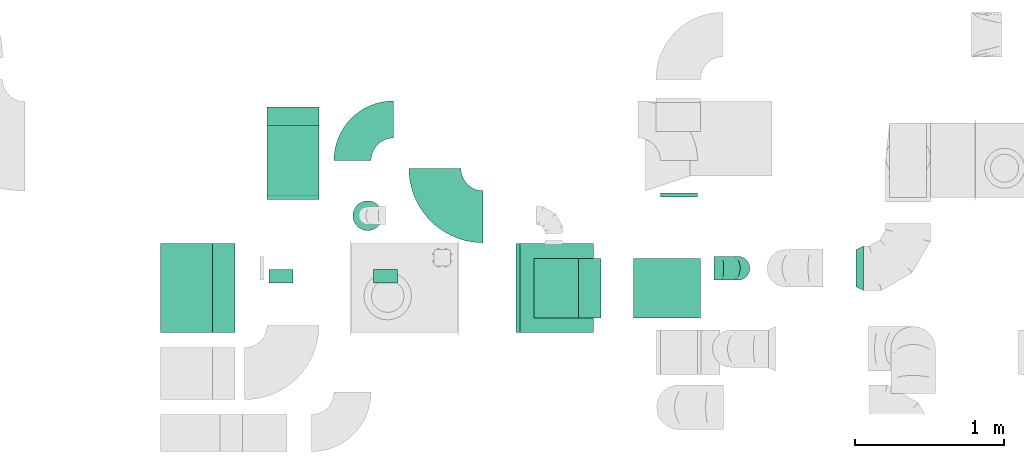
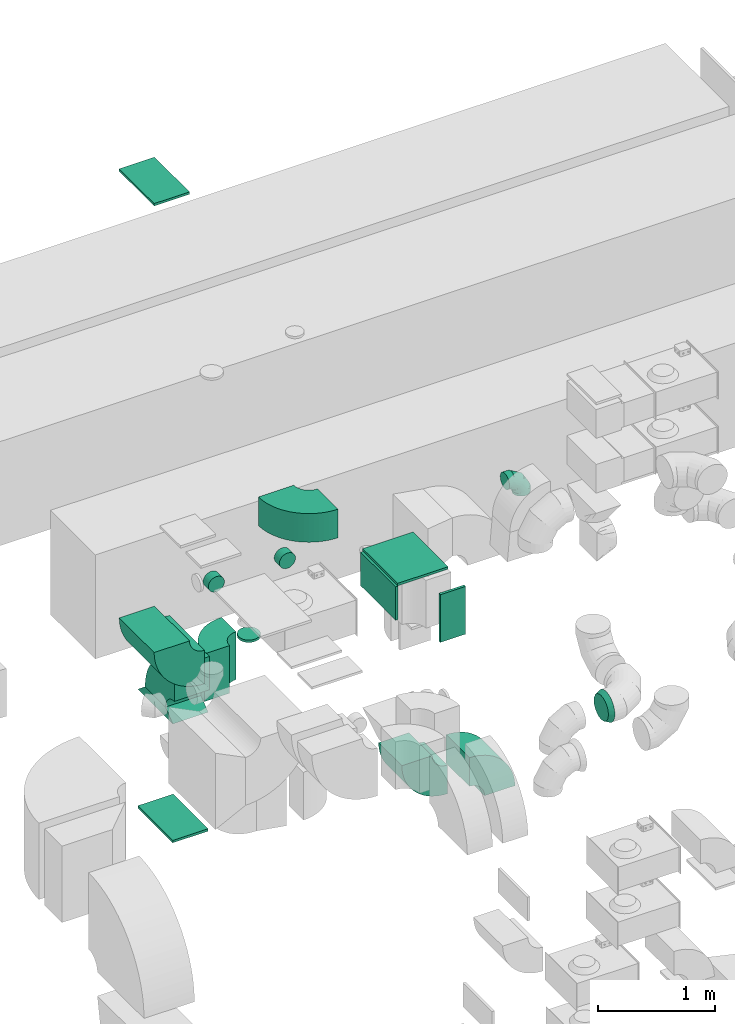
# One storey, part 10 of 59: 17 flow fittings.
"""IFC2X3 building model written with IfcOpenShell, lengths in millimetres."""

import ifcopenshell
import ifcopenshell.guid

model = None  # the IFC model being written
_history = None  # IfcOwnerHistory: only IFC2X3 demands one
_inside = {}  # id of a spatial element -> (the spatial element, [elements in it])
_under = {}  # id of a project, library or spatial element -> (it, [spatial elements below it])
_declared = {}  # id of a project -> (the project, [libraries it declares])
_typed = {}  # id of a type object -> (the type object, [elements of that type])
_made_of = {}  # id of a material, layer set ... -> (it, [elements and type objects made of it])


def new_model(schema):
    """Start an empty IFC model of exactly this schema.

    Asked for "IFC4X3", IfcOpenShell would pick the latest addendum, in which some entities
    have other attributes; the version numbers below select the first issue.
    IFC2X3 requires an IfcOwnerHistory on every rooted entity: one is made here for all.
    """
    global model, _history
    if schema == "IFC4X3":
        model = ifcopenshell.file(schema_version=(4, 3, 0, 0))
    else:
        model = ifcopenshell.file(schema=schema)
    _inside.clear()
    _under.clear()
    _declared.clear()
    _typed.clear()
    _made_of.clear()
    _history = None
    if model.schema == "IFC2X3":
        org = make("IfcOrganization", Name="unknown")
        user = make(
            "IfcPersonAndOrganization",
            ThePerson=make("IfcPerson", FamilyName="unknown"),
            TheOrganization=org,
        )
        app = make(
            "IfcApplication",
            ApplicationDeveloper=org,
            Version="unknown",
            ApplicationFullName="unknown",
            ApplicationIdentifier="unknown",
        )
        _history = make(
            "IfcOwnerHistory",
            OwningUser=user,
            OwningApplication=app,
            ChangeAction="ADDED",
            CreationDate=0,
        )
    return model


def make(cls, **values):
    """One entity of the class cls with the attributes given. An attribute that is None is left unset."""
    return model.create_entity(
        cls, **{name: value for name, value in values.items() if value is not None}
    )


def entity(cls, *values):
    """Any entity or typed value of the class cls, its attributes in the order of the schema. None: left unset."""
    e = model.create_entity(cls)
    for i, value in enumerate(values):
        if value is not None:
            e[i] = value
    return e


def rooted(cls, **values):
    """An entity with a GlobalId (a new one), such as an element, a storey or a relation."""
    return make(cls, GlobalId=ifcopenshell.guid.new(), OwnerHistory=_history, **values)


def si_unit(unit_type, name, prefix=None):
    """IfcSIUnit, for example si_unit("LENGTHUNIT", "METRE", prefix="MILLI")."""
    return make("IfcSIUnit", UnitType=unit_type, Prefix=prefix, Name=name)


def converted_unit(unit_type, name, factor, base, dimensions=None, offset=None):
    """IfcConversionBasedUnit, such as the inch: factor (a typed value) times the base unit."""
    return make(
        "IfcConversionBasedUnit"
        if offset is None
        else "IfcConversionBasedUnitWithOffset",
        ConversionOffset=offset,
        Dimensions=None
        if dimensions is None
        else entity("IfcDimensionalExponents", *dimensions),
        UnitType=unit_type,
        Name=name,
        ConversionFactor=make(
            "IfcMeasureWithUnit", ValueComponent=factor, UnitComponent=base
        ),
    )


def derived_unit(unit_type, elements):
    """IfcDerivedUnit: a product of units, each with its exponent."""
    return make(
        "IfcDerivedUnit",
        Elements=[
            make("IfcDerivedUnitElement", Unit=unit, Exponent=power)
            for unit, power in elements
        ],
        UnitType=unit_type,
    )


def assignment(units):
    """IfcUnitAssignment: the units of a project."""
    return None if units is None else make("IfcUnitAssignment", Units=units)


def point(xyz):
    """IfcCartesianPoint."""
    return None if xyz is None else make("IfcCartesianPoint", Coordinates=xyz)


def direction(xyz):
    """IfcDirection."""
    return None if xyz is None else make("IfcDirection", DirectionRatios=xyz)


def frame(location, z_axis=None, x_axis=None):
    """IfcAxis2Placement3D, a coordinate frame: its origin and axes. An axis left out is left unset."""
    return make(
        "IfcAxis2Placement3D",
        Location=point(location),
        Axis=direction(z_axis),
        RefDirection=direction(x_axis),
    )


def frame_2d(location, x_axis=None):
    """IfcAxis2Placement2D, a coordinate frame in the plane: its origin and x axis."""
    return make(
        "IfcAxis2Placement2D", Location=point(location), RefDirection=direction(x_axis)
    )


def origin():
    """The frame at (0, 0, 0) with its axes left unset."""
    return frame((0.0, 0.0, 0.0))


def origin_2d_with_axis():
    """The frame at (0, 0) in the plane with the x axis (1, 0) written out."""
    return frame_2d((0.0, 0.0), x_axis=(1.0, 0.0))


def place(relative_to, where):
    """IfcLocalPlacement: puts the frame where relative to a parent placement (None: the world)."""
    return make(
        "IfcLocalPlacement", PlacementRelTo=relative_to, RelativePlacement=where
    )


def context(
    kind, dimensions, precision=None, world=None, true_north=None, identifier=None
):
    """IfcGeometricRepresentationContext, for example the 3D "Model" context."""
    return make(
        "IfcGeometricRepresentationContext",
        ContextIdentifier=identifier,
        ContextType=kind,
        CoordinateSpaceDimension=dimensions,
        Precision=precision,
        WorldCoordinateSystem=world,
        TrueNorth=true_north,
    )


def subcontext(parent, identifier, kind, view, scale=None):
    """IfcGeometricRepresentationSubContext, for example "Body" below "Model"."""
    return make(
        "IfcGeometricRepresentationSubContext",
        ContextIdentifier=identifier,
        ContextType=kind,
        ParentContext=parent,
        TargetScale=scale,
        TargetView=view,
    )


def project(units=None, contexts=None):
    """IfcProject with its units and contexts."""
    return rooted(
        "IfcProject",
        Name="project",
        RepresentationContexts=contexts,
        UnitsInContext=assignment(units),
    )


def spatial(cls, under=None, at=None, **own):
    """A site, building, storey or space (cls), placed at a placement, below another one or the project."""
    s = rooted(cls, ObjectPlacement=at, **own)
    if under is not None:
        _under.setdefault(under.id(), (under, []))[1].append(s)
    return s


def polyline(points):
    """IfcPolyline through the points."""
    return make("IfcPolyline", Points=[point(p) for p in points])


def circle_curve(where, radius):
    """IfcCircle in the frame where."""
    return make("IfcCircle", Position=where, Radius=radius)


def parameter(value):
    """IfcParameterValue: where a trimmed curve begins or ends, as a parameter of its basis curve."""
    return model.create_entity("IfcParameterValue", value)


def trimmed(basis, trim1, trim2, sense, master):
    """IfcTrimmedCurve: the piece of a basis curve between two trims."""
    return make(
        "IfcTrimmedCurve",
        BasisCurve=basis,
        Trim1=trim1,
        Trim2=trim2,
        SenseAgreement=sense,
        MasterRepresentation=master,
    )


def segment(curve, same_sense, transition):
    """IfcCompositeCurveSegment."""
    return make(
        "IfcCompositeCurveSegment",
        Transition=transition,
        SameSense=same_sense,
        ParentCurve=curve,
    )


def composite_curve(segments, self_intersect=None):
    """IfcCompositeCurve: segments joined end to end."""
    return make("IfcCompositeCurve", Segments=segments, SelfIntersect=self_intersect)


def profile(cls, at=None, kind="AREA", **sizes):
    """A parametric profile (cls). Its sizes go by their IFC names, for example OverallWidth=200.0."""
    return make(cls, ProfileType=kind, Position=at, **sizes)


def rectangle(**sizes):
    """IfcRectangleProfileDef."""
    return profile("IfcRectangleProfileDef", **sizes)


def circle(**sizes):
    """IfcCircleProfileDef."""
    return profile("IfcCircleProfileDef", **sizes)


def outline(outer, holes=None, kind="AREA"):
    """IfcArbitraryClosedProfileDef: a profile drawn as a closed curve; with holes, ...WithVoids."""
    if holes is None:
        return make("IfcArbitraryClosedProfileDef", ProfileType=kind, OuterCurve=outer)
    return make(
        "IfcArbitraryProfileDefWithVoids",
        ProfileType=kind,
        OuterCurve=outer,
        InnerCurves=holes,
    )


def extrude(swept, where, along, depth):
    """IfcExtrudedAreaSolid: the profile swept, set in the frame where, extruded along a direction by depth."""
    return make(
        "IfcExtrudedAreaSolid",
        SweptArea=swept,
        Position=where,
        ExtrudedDirection=direction(along),
        Depth=depth,
    )


def faces_of(points, faces, orient=None, outer=None):
    """IfcFace entities. A face is a list of loops; a loop is a list of indices into points, from 0.

    orient and outer hold one flag for each loop. By default every Orientation is true, the
    first loop of a face is its IfcFaceOuterBound and the others are IfcFaceBound.
    """
    made = []
    for i, loops in enumerate(faces):
        bounds = []
        for j, loop in enumerate(loops):
            is_outer = j == 0 if outer is None else outer[i][j]
            bounds.append(
                make(
                    "IfcFaceOuterBound" if is_outer else "IfcFaceBound",
                    Bound=make("IfcPolyLoop", Polygon=[points[k] for k in loop]),
                    Orientation=True if orient is None else orient[i][j],
                )
            )
        made.append(make("IfcFace", Bounds=bounds))
    return made


def faceted_brep(points, faces, orient=None, outer=None, voids=None):
    """IfcFacetedBrep: a solid bounded by flat faces; with voids (closed shells), ...WithVoids."""
    shared = [point(p) for p in points]
    hull = make("IfcClosedShell", CfsFaces=faces_of(shared, faces, orient, outer))
    if voids is None:
        return make("IfcFacetedBrep", Outer=hull)
    return make(
        "IfcFacetedBrepWithVoids",
        Outer=hull,
        Voids=[
            make(cls, CfsFaces=faces_of(shared, fs, o, b)) for cls, fs, o, b in voids
        ],
    )


def shape(context_of_items, identifier, shape_type, items):
    """IfcShapeRepresentation: the items that make up one representation, for example the "Body"."""
    return make(
        "IfcShapeRepresentation",
        ContextOfItems=context_of_items,
        RepresentationIdentifier=identifier,
        RepresentationType=shape_type,
        Items=items,
    )


def source(mapping_origin, context_of_items, identifier, shape_type, items):
    """IfcRepresentationMap: a shape defined once, which mapped items show again and again."""
    return make(
        "IfcRepresentationMap",
        MappingOrigin=mapping_origin,
        MappedRepresentation=shape(context_of_items, identifier, shape_type, items),
    )


def transform(
    local_origin,
    x_axis=None,
    y_axis=None,
    z_axis=None,
    scale=None,
    scale2=None,
    scale3=None,
    uniform=True,
):
    """IfcCartesianTransformationOperator3D, or its non-uniform kind. x_axis, y_axis, z_axis: its Axis1, 2, 3."""
    if uniform:
        return make(
            "IfcCartesianTransformationOperator3D",
            Axis1=direction(x_axis),
            Axis2=direction(y_axis),
            LocalOrigin=point(local_origin),
            Scale=scale,
            Axis3=direction(z_axis),
        )
    return make(
        "IfcCartesianTransformationOperator3DnonUniform",
        Axis1=direction(x_axis),
        Axis2=direction(y_axis),
        LocalOrigin=point(local_origin),
        Scale=scale,
        Axis3=direction(z_axis),
        Scale2=scale2,
        Scale3=scale3,
    )


def mapped(mapping_source, mapping_target):
    """IfcMappedItem: shows the shape of a source again, moved by a transform."""
    return make(
        "IfcMappedItem", MappingSource=mapping_source, MappingTarget=mapping_target
    )


def material(Name=None, Category=None):
    """IfcMaterial."""
    return make("IfcMaterial", Name=Name, Category=Category)


def made_of(thing, what):
    """Note that an element or type object is made of a material, layer set ...; save() writes the relation."""
    if what is not None:
        _made_of.setdefault(what.id(), (what, []))[1].append(thing)
    return thing


def type_object(cls, material=None, **own):
    """A type object (cls), such as IfcWallType, which elements share."""
    return made_of(rooted(cls, **own), material)


def type_shapes(of_type, sources):
    """Give a type object the sources (RepresentationMaps) that its elements show as mapped items."""
    of_type.RepresentationMaps = sources


def element(
    cls,
    number,
    at=None,
    inside=None,
    cuts=None,
    type_object=None,
    material=None,
    context=None,
    identifier="Body",
    shape_type=None,
    held_by="IfcProductDefinitionShape",
    body=None,
    shapes=None,
    **own,
):
    """One element of the class cls, such as IfcWall. Its Tag is "e" and its number.

    at: its placement. inside: the storey or other place that contains it. cuts: it is an
    opening in that element (IfcRelVoidsElement). A single representation is given by context,
    identifier, shape_type and body (its items); several are given by shapes. held_by: the class
    of the entity that holds the representations. save() writes the other relations.
    """
    e = rooted(cls, Tag="e%d" % number, ObjectPlacement=at, **own)
    if body is not None:
        shapes = [shape(context, identifier, shape_type, body)]
    if shapes is not None:
        e.Representation = make(held_by, Representations=shapes)
    if inside is not None:
        _inside.setdefault(inside.id(), (inside, []))[1].append(e)
    if cuts is not None:
        rooted(
            "IfcRelVoidsElement", RelatingBuildingElement=cuts, RelatedOpeningElement=e
        )
    if type_object is not None:
        _typed.setdefault(type_object.id(), (type_object, []))[1].append(e)
    return made_of(e, material)


def aggregate(whole, parts):
    """IfcRelAggregates: a whole, such as a stair, and the parts it consists of."""
    return rooted("IfcRelAggregates", RelatingObject=whole, RelatedObjects=parts)


def save(model, path):
    """Write the relations noted so far, then the file.

    IfcRelAggregates (storeys below a building ...), IfcRelContainedInSpatialStructure (elements
    in a storey), IfcRelDefinesByType, IfcRelAssociatesMaterial and IfcRelDeclares: one each for
    every whole, place, type object, material and project.
    """
    for whole, parts in _under.values():
        aggregate(whole, parts)
    for where, things in _inside.values():
        rooted(
            "IfcRelContainedInSpatialStructure",
            RelatedElements=things,
            RelatingStructure=where,
        )
    for kind, things in _typed.values():
        rooted("IfcRelDefinesByType", RelatedObjects=things, RelatingType=kind)
    for what, things in _made_of.values():
        rooted("IfcRelAssociatesMaterial", RelatedObjects=things, RelatingMaterial=what)
    for by, libraries in _declared.values():
        rooted("IfcRelDeclares", RelatingContext=by, RelatedDefinitions=libraries)
    model.write(path)


model = new_model("IFC2X3")

# Units and contexts
model_context = context("Model", 3, precision=0.01, world=origin(), true_north=direction((6.12303176911189e-17, 1.0)))
body_context = subcontext(model_context, "Body", "Model", "MODEL_VIEW")
ifc_project = project(units=[si_unit("LENGTHUNIT", "METRE", prefix="MILLI"), si_unit("AREAUNIT", "SQUARE_METRE"), si_unit("VOLUMEUNIT", "CUBIC_METRE"), converted_unit("PLANEANGLEUNIT", "DEGREE", entity("IfcRatioMeasure", 0.0174532925199433), si_unit("PLANEANGLEUNIT", "RADIAN"), dimensions=[0, 0, 0, 0, 0, 0, 0]), si_unit("MASSUNIT", "GRAM", prefix="KILO"), derived_unit("MASSDENSITYUNIT", [(si_unit("MASSUNIT", "GRAM", prefix="KILO"), 1), (si_unit("LENGTHUNIT", "METRE"), -3)]), derived_unit("MOMENTOFINERTIAUNIT", [(si_unit("LENGTHUNIT", "METRE"), 4)]), si_unit("TIMEUNIT", "SECOND"), si_unit("FREQUENCYUNIT", "HERTZ"), si_unit("THERMODYNAMICTEMPERATUREUNIT", "DEGREE_CELSIUS"), derived_unit("THERMALTRANSMITTANCEUNIT", [(si_unit("MASSUNIT", "GRAM", prefix="KILO"), 1), (si_unit("THERMODYNAMICTEMPERATUREUNIT", "KELVIN"), -1), (si_unit("TIMEUNIT", "SECOND"), -3)]), derived_unit("VOLUMETRICFLOWRATEUNIT", [(si_unit("LENGTHUNIT", "METRE"), 3), (si_unit("TIMEUNIT", "SECOND"), -1)]), derived_unit("MASSFLOWRATEUNIT", [(si_unit("MASSUNIT", "GRAM", prefix="KILO"), 1), (si_unit("TIMEUNIT", "SECOND"), -1)]), derived_unit("ROTATIONALFREQUENCYUNIT", [(si_unit("TIMEUNIT", "SECOND"), -1)]), si_unit("ELECTRICCURRENTUNIT", "AMPERE"), si_unit("ELECTRICVOLTAGEUNIT", "VOLT"), si_unit("POWERUNIT", "WATT"), si_unit("FORCEUNIT", "NEWTON", prefix="KILO"), si_unit("ILLUMINANCEUNIT", "LUX"), si_unit("LUMINOUSFLUXUNIT", "LUMEN"), si_unit("LUMINOUSINTENSITYUNIT", "CANDELA"), derived_unit("USERDEFINED", [(si_unit("MASSUNIT", "GRAM", prefix="KILO"), -1), (si_unit("LENGTHUNIT", "METRE"), -2), (si_unit("TIMEUNIT", "SECOND"), 3), (si_unit("LUMINOUSFLUXUNIT", "LUMEN"), 1)]), derived_unit("LINEARVELOCITYUNIT", [(si_unit("LENGTHUNIT", "METRE"), 1), (si_unit("TIMEUNIT", "SECOND"), -1)]), si_unit("PRESSUREUNIT", "PASCAL"), derived_unit("USERDEFINED", [(si_unit("LENGTHUNIT", "METRE"), -2), (si_unit("MASSUNIT", "GRAM", prefix="KILO"), 1), (si_unit("TIMEUNIT", "SECOND"), -2)]), derived_unit("LINEARFORCEUNIT", [(si_unit("MASSUNIT", "GRAM", prefix="KILO"), 1), (si_unit("LENGTHUNIT", "METRE"), 1), (si_unit("TIMEUNIT", "SECOND"), -2), (si_unit("LENGTHUNIT", "METRE"), -1)]), derived_unit("PLANARFORCEUNIT", [(si_unit("MASSUNIT", "GRAM", prefix="KILO"), 1), (si_unit("LENGTHUNIT", "METRE"), 1), (si_unit("TIMEUNIT", "SECOND"), -2), (si_unit("LENGTHUNIT", "METRE"), -2)])], contexts=[model_context])

# Site, building, storey
site_placement = place(None, origin())
site = spatial("IfcSite", under=ifc_project, at=site_placement, CompositionType="ELEMENT")
building_placement = place(site_placement, origin())
building = spatial("IfcBuilding", under=site, at=building_placement, CompositionType="ELEMENT")
storey_placement = place(building_placement, frame((0.0, 0.0, 28200.0)))
storey = spatial("IfcBuildingStorey", under=building, at=storey_placement, CompositionType="ELEMENT", Elevation=28200.0)

# Flow fittings
ifc_material = material()
duct_fitting_type_1 = type_object("IfcDuctFittingType", PredefinedType="NOTDEFINED", material=ifc_material)
shared_shape_1 = source(origin(), body_context, "Body", "SweptSolid", [
    extrude(rectangle(XDim=26.0960000002817, YDim=500.0, at=origin_2d_with_axis()), frame((6.95, 0.0, -125.0)), (0.0, 0.0, 1.0), 250.0),
])
type_shapes(duct_fitting_type_1, [shared_shape_1])
flow_fitting_1_placement = place(storey_placement, frame((31140.11, 12664.49, 1600.01), z_axis=(1.0, 0.0, 0.0), x_axis=(0.0, 1.0, 0.0)))
element("IfcFlowFitting", 1, at=flow_fitting_1_placement, inside=storey, type_object=duct_fitting_type_1, material=ifc_material, context=body_context, shape_type="MappedRepresentation", body=[
    mapped(shared_shape_1, transform((0.0, 0.0, 0.0), scale=1.0)),
])
duct_fitting_type_2 = type_object("IfcDuctFittingType", PredefinedType="NOTDEFINED", material=ifc_material)
shared_shape_2 = source(origin(), body_context, "Body", "SweptSolid", [
    extrude(rectangle(XDim=24.9999999999999, YDim=600.0, at=origin_2d_with_axis()), frame((12.5, 0.0, -250.0)), (0.0, 0.0, 1.0), 500.0),
])
type_shapes(duct_fitting_type_2, [shared_shape_2])
flow_fitting_2_placement = place(storey_placement, frame((30315.03, 12045.06, 2830.0), z_axis=(-1.0, 0.0, 0.0), x_axis=(0.0, 0.0, 1.0)))
element("IfcFlowFitting", 2, at=flow_fitting_2_placement, inside=storey, type_object=duct_fitting_type_2, material=ifc_material, context=body_context, shape_type="MappedRepresentation", body=[
    mapped(shared_shape_2, transform((0.0, 0.0, 0.0), scale=1.0)),
])
duct_fitting_type_3 = type_object("IfcDuctFittingType", PredefinedType="NOTDEFINED", material=ifc_material)
shared_shape_3 = source(origin(), body_context, "Body", "SweptSolid", [
    extrude(circle(Radius=99.9999999999994, at=origin_2d_with_axis()), frame((0.0, 0.0, 0.0), z_axis=(1.0, 0.0, 0.0), x_axis=(0.0, 1.0, 0.0)), (0.0, 0.0, 1.0), 25.0000000000018),
])
type_shapes(duct_fitting_type_3, [shared_shape_3])
flow_fitting_3_placement = place(storey_placement, frame((29046.64, 12532.56, 2210.43), z_axis=(-1.0, 0.0, 0.0), x_axis=(0.0, 0.0, -1.0)))
element("IfcFlowFitting", 3, at=flow_fitting_3_placement, inside=storey, type_object=duct_fitting_type_3, material=ifc_material, context=body_context, shape_type="MappedRepresentation", body=[
    mapped(shared_shape_3, transform((0.0, 0.0, 0.0), scale=1.0)),
])
duct_fitting_type_4 = type_object("IfcDuctFittingType", PredefinedType="NOTDEFINED", material=ifc_material)
shared_shape_4 = source(origin(), body_context, "Body", "SweptSolid", [
    extrude(rectangle(XDim=24.9999999999999, YDim=600.0, at=origin_2d_with_axis()), frame((12.5, 0.0, -175.0)), (0.0, 0.0, 1.0), 350.0),
])
type_shapes(duct_fitting_type_4, [shared_shape_4])
flow_fitting_4_placement = place(storey_placement, frame((27829.24, 12045.06, 7650.0), z_axis=(1.0, 0.0, 0.0), x_axis=(0.0, 0.0, 1.0)))
element("IfcFlowFitting", 4, at=flow_fitting_4_placement, inside=storey, type_object=duct_fitting_type_4, material=ifc_material, context=body_context, shape_type="MappedRepresentation", body=[
    mapped(shared_shape_4, transform((0.0, 0.0, 0.0), scale=1.0)),
])
duct_fitting_type_5 = type_object("IfcDuctFittingType", PredefinedType="NOTDEFINED", material=ifc_material)
shared_shape_5 = source(origin(), body_context, "Body", "SweptSolid", [
    extrude(outline(polyline([(-175.0, -50.0), (175.0, -50.0), (300.0, 50.0), (-300.0, 50.0), (-175.0, -50.0)])), frame((50.0, -175.0, 0.0), z_axis=(-2.50000759891115e-07, 1.0, 0.0), x_axis=(0.0, 0.0, 1.0)), (0.0, 0.0, 1.0), 350.000000000011),
])
type_shapes(duct_fitting_type_5, [shared_shape_5])
flow_fitting_5_placement = place(storey_placement, frame((28545.03, 12964.59, 1520.0), z_axis=(0.0, -1.0, 0.0), x_axis=(0.0, 0.0, -1.0)))
element("IfcFlowFitting", 5, at=flow_fitting_5_placement, inside=storey, type_object=duct_fitting_type_5, material=ifc_material, context=body_context, shape_type="MappedRepresentation", body=[
    mapped(shared_shape_5, transform((0.0, 0.0, 0.0), scale=1.0)),
])
duct_fitting_type_6 = type_object("IfcDuctFittingType", PredefinedType="NOTDEFINED", material=ifc_material)
shared_shape_6 = source(origin(), body_context, "Body", "SweptSolid", [
    extrude(rectangle(XDim=26.0960000000005, YDim=350.0, at=origin_2d_with_axis()), frame((6.95, 0.0, -300.0)), (0.0, 0.0, 1.0), 600.0),
])
type_shapes(duct_fitting_type_6, [shared_shape_6])
flow_fitting_6_placement = place(storey_placement, frame((30065.03, 12045.06, 2650.0), z_axis=(0.0, 1.0, 0.0), x_axis=(-1.0, 0.0, 0.0)))
element("IfcFlowFitting", 6, at=flow_fitting_6_placement, inside=storey, type_object=duct_fitting_type_6, material=ifc_material, context=body_context, shape_type="MappedRepresentation", body=[
    mapped(shared_shape_6, transform((0.0, 0.0, 0.0), scale=1.0)),
])
duct_fitting_type_7 = type_object("IfcDuctFittingType", PredefinedType="NOTDEFINED", material=ifc_material)
shared_shape_7 = source(origin(), body_context, "Body", "SweptSolid", [
    extrude(rectangle(XDim=24.9999999999999, YDim=350.0, at=origin_2d_with_axis()), frame((12.5, 0.0, -300.0)), (0.0, 0.0, 1.0), 600.0),
])
type_shapes(duct_fitting_type_7, [shared_shape_7])
flow_fitting_7_placement = place(storey_placement, frame((28545.03, 12964.59, 200.0), z_axis=(0.0, -1.0, 0.0), x_axis=(0.0, 0.0, -1.0)))
element("IfcFlowFitting", 7, at=flow_fitting_7_placement, inside=storey, type_object=duct_fitting_type_7, material=ifc_material, context=body_context, shape_type="MappedRepresentation", body=[
    mapped(shared_shape_7, transform((0.0, 0.0, 0.0), scale=1.0)),
])
duct_fitting_type_8 = type_object("IfcDuctFittingType", PredefinedType="NOTDEFINED", material=ifc_material)
shared_shape_8 = source(origin(), body_context, "Body", "Brep", [
    faceted_brep([(-160.0, 0.0, -80.0), (-160.0, -20.71, -77.27), (-160.0, -40.0, -69.28), (-160.0, -56.57, -56.57), (-160.0, -69.28, -40.0), (-160.0, -77.27, -20.71), (-160.0, -80.0, 0.0), (-160.0, -77.27, 20.71), (-160.0, -69.28, 40.0), (-160.0, -56.57, 56.57), (-160.0, -40.0, 69.28), (-160.0, -20.71, 77.27), (-160.0, 0.0, 80.0), (-160.0, 20.71, 77.27), (-160.0, 40.0, 69.28), (-160.0, 56.57, 56.57), (-160.0, 69.28, 40.0), (-160.0, 77.27, 20.71), (-160.0, 80.0, 0.0), (-160.0, 77.27, -20.71), (-160.0, 69.28, -40.0), (-160.0, 56.57, -56.57), (-160.0, 40.0, -69.28), (-160.0, 20.71, -77.27), (-122.68, 20.71, 77.27), (-127.85, 40.0, 69.28), (-117.13, 0.0, 80.0), (-132.29, 56.57, 56.57), (-137.83, 77.27, 20.71), (-138.56, 80.0, 0.0), (-135.69, 69.28, 40.0), (-135.69, 69.28, -40.0), (-132.29, 56.57, -56.57), (-137.83, 77.27, -20.71), (-122.68, 20.71, -77.27), (-117.13, 0.0, -80.0), (-127.85, 40.0, -69.28), (-111.58, -20.71, -77.27), (-106.41, -40.0, -69.28), (-101.97, -56.57, -56.57), (-98.56, -69.28, -40.0), (-96.42, -77.27, -20.71), (-95.69, -80.0, 0.0), (-96.42, -77.27, 20.71), (-98.56, -69.28, 40.0), (-101.97, -56.57, 56.57), (-106.41, -40.0, 69.28), (-111.58, -20.71, 77.27), (-58.03, 58.03, 77.27), (-72.15, 72.15, 69.28), (-42.87, 42.87, 80.0), (-84.28, 84.28, 56.57), (-93.59, 93.59, 40.0), (-99.44, 99.44, 20.71), (-101.44, 101.44, 0.0), (-99.44, 99.44, -20.71), (-93.59, 93.59, -40.0), (-84.28, 84.28, -56.57), (-58.03, 58.03, -77.27), (-42.87, 42.87, -80.0), (-72.15, 72.15, -69.28), (-27.71, 27.71, -77.27), (-13.59, 13.59, -69.28), (-1.46, 1.46, -56.57), (7.85, -7.85, -40.0), (13.7, -13.7, -20.71), (15.69, -15.69, 0.0), (13.7, -13.7, 20.71), (7.85, -7.85, 40.0), (-1.46, 1.46, 56.57), (-13.59, 13.59, 69.28), (-27.71, 27.71, 77.27), (-20.71, 122.68, 77.27), (-40.0, 127.85, 69.28), (0.0, 117.13, 80.0), (-56.57, 132.29, 56.57), (-69.28, 135.69, 40.0), (-77.27, 137.83, 20.71), (-80.0, 138.56, 0.0), (-77.27, 137.83, -20.71), (-69.28, 135.69, -40.0), (-56.57, 132.29, -56.57), (-20.71, 122.68, -77.27), (0.0, 117.13, -80.0), (-40.0, 127.85, -69.28), (20.71, 111.58, -77.27), (40.0, 106.41, -69.28), (56.57, 101.97, -56.57), (69.28, 98.56, -40.0), (77.27, 96.42, -20.71), (80.0, 95.69, 0.0), (77.27, 96.42, 20.71), (69.28, 98.56, 40.0), (56.57, 101.97, 56.57), (40.0, 106.41, 69.28), (20.71, 111.58, 77.27), (-20.71, 160.0, -77.27), (-40.0, 160.0, -69.28), (-56.57, 160.0, -56.57), (-69.28, 160.0, -40.0), (-77.27, 160.0, -20.71), (-80.0, 160.0, 0.0), (-77.27, 160.0, 20.71), (-69.28, 160.0, 40.0), (-56.57, 160.0, 56.57), (-40.0, 160.0, 69.28), (-20.71, 160.0, 77.27), (0.0, 160.0, 80.0), (20.71, 160.0, 77.27), (40.0, 160.0, 69.28), (56.57, 160.0, 56.57), (69.28, 160.0, 40.0), (77.27, 160.0, 20.71), (80.0, 160.0, 0.0), (77.27, 160.0, -20.71), (69.28, 160.0, -40.0), (56.57, 160.0, -56.57), (40.0, 160.0, -69.28), (20.71, 160.0, -77.27), (0.0, 160.0, -80.0)], [[[0, 1, 2, 3, 4, 5, 6, 7, 8, 9, 10, 11, 12, 13, 14, 15, 16, 17, 18, 19, 20, 21, 22, 23]], [[24, 25, 14, 13]], [[26, 24, 13, 12]], [[14, 25, 27, 15]], [[28, 29, 18, 17]], [[30, 28, 17, 16]], [[15, 27, 30, 16]], [[20, 31, 32, 21]], [[33, 31, 20, 19]], [[18, 29, 33, 19]], [[34, 35, 0, 23]], [[36, 34, 23, 22]], [[32, 36, 22, 21]], [[1, 0, 35, 37]], [[2, 1, 37, 38]], [[3, 2, 38, 39]], [[5, 4, 40, 41]], [[6, 5, 41, 42]], [[39, 40, 4, 3]], [[6, 42, 43, 7]], [[7, 43, 44, 8]], [[8, 44, 45, 9]], [[9, 45, 46, 10]], [[10, 46, 47, 11]], [[26, 12, 11, 47]], [[48, 49, 25, 24]], [[50, 48, 24, 26]], [[27, 25, 49, 51]], [[52, 53, 28, 30]], [[51, 52, 30, 27]], [[29, 28, 53, 54]], [[55, 56, 31, 33]], [[54, 55, 33, 29]], [[32, 31, 56, 57]], [[58, 59, 35, 34]], [[60, 58, 34, 36]], [[57, 60, 36, 32]], [[37, 35, 59, 61]], [[38, 37, 61, 62]], [[39, 38, 62, 63]], [[41, 40, 64, 65]], [[42, 41, 65, 66]], [[63, 64, 40, 39]], [[43, 42, 66, 67]], [[44, 43, 67, 68]], [[68, 69, 45, 44]], [[46, 45, 69, 70]], [[47, 46, 70, 71]], [[26, 47, 71, 50]], [[72, 73, 49, 48]], [[74, 72, 48, 50]], [[51, 49, 73, 75]], [[76, 77, 53, 52]], [[75, 76, 52, 51]], [[54, 53, 77, 78]], [[79, 80, 56, 55]], [[78, 79, 55, 54]], [[57, 56, 80, 81]], [[82, 83, 59, 58]], [[84, 82, 58, 60]], [[81, 84, 60, 57]], [[61, 59, 83, 85]], [[62, 61, 85, 86]], [[63, 62, 86, 87]], [[65, 64, 88, 89]], [[66, 65, 89, 90]], [[87, 88, 64, 63]], [[67, 66, 90, 91]], [[68, 67, 91, 92]], [[92, 93, 69, 68]], [[70, 69, 93, 94]], [[71, 70, 94, 95]], [[50, 71, 95, 74]], [[96, 97, 98, 99, 100, 101, 102, 103, 104, 105, 106, 107, 108, 109, 110, 111, 112, 113, 114, 115, 116, 117, 118, 119]], [[72, 74, 107, 106]], [[73, 72, 106, 105]], [[75, 73, 105, 104]], [[77, 76, 103, 102]], [[78, 77, 102, 101]], [[75, 104, 103, 76]], [[78, 101, 100, 79]], [[79, 100, 99, 80]], [[80, 99, 98, 81]], [[84, 97, 96, 82]], [[82, 96, 119, 83]], [[84, 81, 98, 97]], [[118, 117, 86, 85]], [[119, 118, 85, 83]], [[116, 87, 86, 117]], [[88, 115, 114, 89]], [[89, 114, 113, 90]], [[115, 88, 87, 116]], [[112, 111, 92, 91]], [[113, 112, 91, 90]], [[111, 110, 93, 92]], [[95, 94, 109, 108]], [[74, 95, 108, 107]], [[110, 109, 94, 93]]]),
])
type_shapes(duct_fitting_type_8, [shared_shape_8])
flow_fitting_8_placement = place(storey_placement, frame((31537.12, 12178.65, 3205.07), z_axis=(0.0, 1.0, 0.0), x_axis=(1.0, 0.0, 0.0)))
element("IfcFlowFitting", 8, at=flow_fitting_8_placement, inside=storey, type_object=duct_fitting_type_8, material=ifc_material, context=body_context, shape_type="MappedRepresentation", body=[
    mapped(shared_shape_8, transform((0.0, 0.0, 0.0), scale=1.0)),
])
duct_fitting_type_9 = type_object("IfcDuctFittingType", PredefinedType="NOTDEFINED", material=ifc_material)
shared_shape_9 = source(origin(), body_context, "Body", "Brep", [
    faceted_brep([(50.0, 101.13, -73.47), (50.0, 118.88, -38.63), (50.0, 125.0, 0.0), (50.0, 118.88, 38.63), (50.0, 101.13, 73.47), (50.0, 73.47, 101.13), (50.0, 38.63, 118.88), (50.0, 0.0, 125.0), (50.0, -38.63, 118.88), (50.0, -73.47, 101.13), (50.0, -101.13, 73.47), (50.0, -118.88, 38.63), (50.0, -125.0, 0.0), (50.0, -118.88, -38.63), (50.0, -101.13, -73.47), (50.0, -73.47, -101.13), (50.0, -38.63, -118.88), (50.0, 0.0, -125.0), (50.0, 38.63, -118.88), (50.0, 73.47, -101.13), (0.0, -150.0, 0.0), (0.0, -144.89, 38.82), (0.0, -129.9, 75.0), (0.0, -106.07, 106.07), (0.0, -75.0, 129.9), (0.0, -38.82, 144.89), (0.0, 0.0, 150.0), (0.0, 38.82, 144.89), (0.0, 75.0, 129.9), (0.0, 106.07, 106.07), (0.0, 129.9, 75.0), (0.0, 144.89, 38.82), (0.0, 150.0, 0.0), (0.0, 144.89, -38.82), (0.0, 129.9, -75.0), (0.0, 106.07, -106.07), (0.0, 75.0, -129.9), (0.0, 38.82, -144.89), (0.0, 0.0, -150.0), (0.0, -38.82, -144.89), (0.0, -75.0, -129.9), (0.0, -106.07, -106.07), (0.0, -129.9, -75.0), (0.0, -144.89, -38.82)], [[[0, 1, 2, 3, 4, 5, 6, 7, 8, 9, 10, 11, 12, 13, 14, 15, 16, 17, 18, 19]], [[20, 21, 22, 23, 24, 25, 26, 27, 28, 29, 30, 31, 32, 33, 34, 35, 36, 37, 38, 39, 40, 41, 42, 43]], [[27, 7, 6]], [[28, 6, 5]], [[27, 26, 7]], [[28, 27, 6]], [[5, 29, 28]], [[3, 2, 31]], [[4, 3, 30]], [[30, 29, 4]], [[31, 30, 3]], [[2, 32, 31]], [[4, 29, 5]], [[21, 12, 11]], [[22, 11, 10]], [[21, 20, 12]], [[22, 21, 11]], [[10, 23, 22]], [[8, 7, 25]], [[9, 8, 24]], [[24, 23, 9]], [[25, 24, 8]], [[7, 26, 25]], [[9, 23, 10]], [[39, 17, 16]], [[40, 16, 15]], [[39, 38, 17]], [[40, 39, 16]], [[15, 41, 40]], [[13, 12, 43]], [[14, 13, 42]], [[42, 41, 14]], [[43, 42, 13]], [[12, 20, 43]], [[14, 41, 15]], [[33, 2, 1]], [[34, 1, 0]], [[33, 32, 2]], [[34, 33, 1]], [[0, 35, 34]], [[18, 17, 37]], [[19, 18, 36]], [[36, 35, 19]], [[37, 36, 18]], [[17, 38, 37]], [[19, 35, 0]]]),
])
type_shapes(duct_fitting_type_9, [shared_shape_9])
flow_fitting_9_placement = place(storey_placement, frame((32380.82, 12178.65, 500.0), z_axis=(0.0, 0.0, 1.0), x_axis=(-1.0, 0.0, 0.0)))
element("IfcFlowFitting", 9, at=flow_fitting_9_placement, inside=storey, type_object=duct_fitting_type_9, material=ifc_material, context=body_context, shape_type="MappedRepresentation", body=[
    mapped(shared_shape_9, transform((0.0, 0.0, 0.0), scale=1.0)),
])
duct_fitting_type_10 = type_object("IfcDuctFittingType", PredefinedType="NOTDEFINED", material=ifc_material)
shared_shape_10 = source(origin(), body_context, "Body", "Brep", [
    faceted_brep([(20.0, 0.0, -80.0), (20.0, 20.71, -77.27), (20.0, 40.0, -69.28), (20.0, 56.57, -56.57), (20.0, 69.28, -40.0), (20.0, 77.27, -20.71), (20.0, 80.0, 0.0), (20.0, 77.27, 20.71), (20.0, 69.28, 40.0), (20.0, 56.57, 56.57), (20.0, 40.0, 69.28), (20.0, 20.71, 77.27), (20.0, 0.0, 80.0), (20.0, -20.71, 77.27), (20.0, -40.0, 69.28), (20.0, -56.57, 56.57), (20.0, -69.28, 40.0), (20.0, -77.27, 20.71), (20.0, -80.0, 0.0), (20.0, -77.27, -20.71), (20.0, -69.28, -40.0), (20.0, -56.57, -56.57), (20.0, -40.0, -69.28), (20.0, -20.71, -77.27), (0.0, 0.0, 80.0), (-70.77, 0.0, 80.0), (-70.77, -20.71, 77.27), (0.0, -20.71, 77.27), (-70.77, -40.0, 69.28), (0.0, -40.0, 69.28), (0.0, -56.57, 56.57), (-70.77, -56.57, 56.57), (0.0, -69.28, 40.0), (-70.77, -69.28, 40.0), (-70.77, -77.27, 20.71), (0.0, -77.27, 20.71), (-70.77, -80.0, 0.0), (0.0, -80.0, 0.0), (-70.77, -77.27, -20.71), (0.0, -77.27, -20.71), (-70.77, -69.28, -40.0), (0.0, -69.28, -40.0), (0.0, -56.57, -56.57), (-70.77, -56.57, -56.57), (0.0, -40.0, -69.28), (-70.77, -40.0, -69.28), (-70.77, -20.71, -77.27), (0.0, -20.71, -77.27), (-70.77, 0.0, -80.0), (0.0, 0.0, -80.0), (-70.77, 20.71, -77.27), (0.0, 20.71, -77.27), (-70.77, 40.0, -69.28), (0.0, 40.0, -69.28), (0.0, 56.57, -56.57), (-70.77, 56.57, -56.57), (0.0, 69.28, -40.0), (-70.77, 69.28, -40.0), (-70.77, 77.27, -20.71), (0.0, 77.27, -20.71), (-70.77, 80.0, 0.0), (0.0, 80.0, 0.0), (-70.77, 77.27, 20.71), (0.0, 77.27, 20.71), (-70.77, 69.28, 40.0), (0.0, 69.28, 40.0), (0.0, 56.57, 56.57), (-70.77, 56.57, 56.57), (0.0, 40.0, 69.28), (-70.77, 40.0, 69.28), (-70.77, 20.71, 77.27), (0.0, 20.71, 77.27)], [[[0, 1, 2, 3, 4, 5, 6, 7, 8, 9, 10, 11, 12, 13, 14, 15, 16, 17, 18, 19, 20, 21, 22, 23]], [[13, 12, 24, 25, 26, 27]], [[14, 13, 27, 26, 28, 29]], [[30, 15, 14, 29, 28, 31]], [[17, 16, 32, 33, 34, 35]], [[18, 17, 35, 34, 36, 37]], [[32, 16, 15, 30, 31, 33]], [[19, 18, 37, 36, 38, 39]], [[20, 19, 39, 38, 40, 41]], [[42, 21, 20, 41, 40, 43]], [[23, 22, 44, 45, 46, 47]], [[0, 23, 47, 46, 48, 49]], [[44, 22, 21, 42, 43, 45]], [[1, 0, 49, 48, 50, 51]], [[2, 1, 51, 50, 52, 53]], [[54, 3, 2, 53, 52, 55]], [[5, 4, 56, 57, 58, 59]], [[6, 5, 59, 58, 60, 61]], [[56, 4, 3, 54, 55, 57]], [[7, 6, 61, 60, 62, 63]], [[8, 7, 63, 62, 64, 65]], [[66, 9, 8, 65, 64, 67]], [[11, 10, 68, 69, 70, 71]], [[12, 11, 71, 70, 25, 24]], [[68, 10, 9, 66, 67, 69]], [[46, 45, 43, 40, 38, 36, 34, 33, 31, 28, 26, 25, 70, 69, 67, 64, 62, 60, 58, 57, 55, 52, 50, 48]]]),
])
type_shapes(duct_fitting_type_10, [shared_shape_10])
for number, where, z_axis, x_axis in (
    (10, (28463.36, 12098.65, 3205.01), (0.0, 0.0, -1.0), (0.0, -1.0, 0.0)),
    (11, (29167.12, 12098.65, 3205.01), (0.0, 0.0, -1.0), (0.0, -1.0, 0.0)),
):
    element("IfcFlowFitting", number, at=place(storey_placement, frame(where, z_axis=z_axis, x_axis=x_axis)), inside=storey, type_object=duct_fitting_type_10, material=ifc_material, context=body_context, shape_type="MappedRepresentation", body=[
        mapped(shared_shape_10, transform((0.0, 0.0, 0.0), scale=1.0)),
    ])
duct_fitting_type_11 = type_object("IfcDuctFittingType", PredefinedType="NOTDEFINED", material=ifc_material)
shared_shape_11 = source(origin(), body_context, "Body", "SweptSolid", [
    extrude(outline(composite_curve([segment(polyline([(-262.5, -137.5), (-12.5, -137.5)]), True, "CONTINUOUS"), segment(trimmed(circle_curve(frame_2d((137.5, -137.5), x_axis=(0.0, 1.0)), 150.0), [parameter(0.0)], [parameter(90.0000000000001)], True, "PARAMETER"), False, "CONTINUOUS"), segment(polyline([(137.5, 12.5), (137.5, 262.5)]), True, "CONTINUOUS"), segment(trimmed(circle_curve(frame_2d((137.5, -137.5), x_axis=(0.0, 1.0)), 400.0), [parameter(0.0)], [parameter(90.0000000000001)], True, "PARAMETER"), True, "CONTINUOUS")], self_intersect=False)), frame((-137.5, 137.5, -250.0), z_axis=(0.0, 0.0, 1.0), x_axis=(-1.0, 0.0, 0.0)), (0.0, 0.0, 1.0), 500.0),
])
type_shapes(duct_fitting_type_11, [shared_shape_11])
flow_fitting_10_placement = place(storey_placement, frame((28945.03, 13179.49, 1600.01), z_axis=(0.0, 0.0, 1.0), x_axis=(-1.0, 0.0, 0.0)))
element("IfcFlowFitting", 12, at=flow_fitting_10_placement, inside=storey, type_object=duct_fitting_type_11, material=ifc_material, context=body_context, shape_type="MappedRepresentation", body=[
    mapped(shared_shape_11, transform((0.0, 0.0, 0.0), scale=1.0)),
])
duct_fitting_type_12 = type_object("IfcDuctFittingType", PredefinedType="NOTDEFINED", material=ifc_material)
shared_shape_12 = source(origin(), body_context, "Body", "SweptSolid", [
    extrude(outline(composite_curve([segment(polyline([(-337.5, -162.5), (12.5, -162.5)]), True, "CONTINUOUS"), segment(trimmed(circle_curve(frame_2d((162.5, -162.5), x_axis=(0.0, 1.0)), 150.0), [parameter(0.0)], [parameter(90.0)], True, "PARAMETER"), False, "CONTINUOUS"), segment(polyline([(162.5, -12.5), (162.5, 337.5)]), True, "CONTINUOUS"), segment(trimmed(circle_curve(frame_2d((162.5, -162.5), x_axis=(0.0, 1.0)), 500.0), [parameter(0.0)], [parameter(90.0)], True, "PARAMETER"), True, "CONTINUOUS")], self_intersect=False)), frame((-162.5, 162.5, -150.0), z_axis=(0.0, 0.0, 1.0), x_axis=(-1.0, 0.0, 0.0)), (0.0, 0.0, 1.0), 300.0),
])
type_shapes(duct_fitting_type_12, [shared_shape_12])
flow_fitting_11_placement = place(storey_placement, frame((29499.08, 12524.99, 3200.0), z_axis=(0.0, 0.0, 1.0), x_axis=(0.0, -1.0, 0.0)))
element("IfcFlowFitting", 13, at=flow_fitting_11_placement, inside=storey, type_object=duct_fitting_type_12, material=ifc_material, context=body_context, shape_type="MappedRepresentation", body=[
    mapped(shared_shape_12, transform((0.0, 0.0, 0.0), scale=1.0)),
])
duct_fitting_type_13 = type_object("IfcDuctFittingType", PredefinedType="NOTDEFINED", material=ifc_material)
shared_shape_13 = source(origin(), body_context, "Body", "SweptSolid", [
    extrude(outline(composite_curve([segment(polyline([(-337.5, -162.5), (12.5, -162.5)]), True, "CONTINUOUS"), segment(trimmed(circle_curve(frame_2d((162.5, -162.5), x_axis=(0.0, 1.0)), 150.0), [parameter(0.0)], [parameter(90.0000000000001)], True, "PARAMETER"), False, "CONTINUOUS"), segment(polyline([(162.5, -12.5), (162.5, 337.5)]), True, "CONTINUOUS"), segment(trimmed(circle_curve(frame_2d((162.5, -162.5), x_axis=(0.0, 1.0)), 500.0), [parameter(0.0)], [parameter(90.0000000000001)], True, "PARAMETER"), True, "CONTINUOUS")], self_intersect=False)), frame((-162.5, 162.5, -300.0), z_axis=(0.0, 0.0, 1.0), x_axis=(-1.0, 0.0, 0.0)), (0.0, 0.0, 1.0), 600.0),
])
type_shapes(duct_fitting_type_13, [shared_shape_13])
flow_fitting_12_placement = place(storey_placement, frame((27829.24, 12045.06, 2650.0), z_axis=(0.0, 1.0, 0.0), x_axis=(-1.0, 0.0, 0.0)))
element("IfcFlowFitting", 14, at=flow_fitting_12_placement, inside=storey, type_object=duct_fitting_type_13, material=ifc_material, context=body_context, shape_type="MappedRepresentation", body=[
    mapped(shared_shape_13, transform((0.0, 0.0, 0.0), scale=1.0)),
])
duct_fitting_type_14 = type_object("IfcDuctFittingType", PredefinedType="NOTDEFINED", material=ifc_material)
shared_shape_14 = source(origin(), body_context, "Body", "SweptSolid", [
    extrude(outline(composite_curve([segment(polyline([(-337.5, -162.5), (12.5, -162.5)]), True, "CONTINUOUS"), segment(trimmed(circle_curve(frame_2d((162.5, -162.5), x_axis=(0.0, 1.0)), 150.0), [parameter(0.0)], [parameter(90.0)], True, "PARAMETER"), False, "CONTINUOUS"), segment(polyline([(162.5, -12.5), (162.5, 337.5)]), True, "CONTINUOUS"), segment(trimmed(circle_curve(frame_2d((162.5, -162.5), x_axis=(0.0, 1.0)), 500.0), [parameter(0.0)], [parameter(90.0)], True, "PARAMETER"), True, "CONTINUOUS")], self_intersect=False)), frame((-162.5, 162.5, -175.0), z_axis=(0.0, 0.0, 1.0), x_axis=(-1.0, 0.0, 0.0)), (0.0, 0.0, 1.0), 350.0),
])
type_shapes(duct_fitting_type_14, [shared_shape_14])
flow_fitting_13_placement = place(storey_placement, frame((28545.03, 12964.59, 1845.0), z_axis=(-1.0, 0.0, 0.0), x_axis=(0.0, 1.0, 0.0)))
element("IfcFlowFitting", 15, at=flow_fitting_13_placement, inside=storey, type_object=duct_fitting_type_14, material=ifc_material, context=body_context, shape_type="MappedRepresentation", body=[
    mapped(shared_shape_14, transform((0.0, 0.0, 0.0), scale=1.0)),
])
duct_fitting_type_15 = type_object("IfcDuctFittingType", PredefinedType="NOTDEFINED", material=ifc_material)
shared_shape_15 = source(origin(), body_context, "Body", "SweptSolid", [
    extrude(outline(composite_curve([segment(polyline([(-300.0, -150.0), (0.0, -150.0)]), True, "CONTINUOUS"), segment(trimmed(circle_curve(frame_2d((150.0, -150.0), x_axis=(0.0, 1.0)), 150.0), [parameter(0.0)], [parameter(90.0)], True, "PARAMETER"), False, "CONTINUOUS"), segment(polyline([(150.0, 0.0), (150.0, 300.0)]), True, "CONTINUOUS"), segment(trimmed(circle_curve(frame_2d((150.0, -150.0), x_axis=(0.0, 1.0)), 450.0), [parameter(0.0)], [parameter(90.0000000000001)], True, "PARAMETER"), True, "CONTINUOUS")], self_intersect=False)), frame((-150.0, 150.0, -200.0), z_axis=(0.0, 0.0, 1.0), x_axis=(-1.0, 0.0, 0.0)), (0.0, 0.0, 1.0), 400.0),
])
type_shapes(duct_fitting_type_15, [shared_shape_15])
for number, where, z_axis, x_axis in (
    (16, (30315.03, 12045.06, 550.0), (0.0, 1.0, 0.0), (-1.0, 0.0, 0.0)),
    (17, (31134.29, 12045.06, 550.0), (0.0, 1.0, 0.0), (1.0, 0.0, 0.0)),
):
    element("IfcFlowFitting", number, at=place(storey_placement, frame(where, z_axis=z_axis, x_axis=x_axis)), inside=storey, type_object=duct_fitting_type_15, material=ifc_material, context=body_context, shape_type="MappedRepresentation", body=[
        mapped(shared_shape_15, transform((0.0, 0.0, 0.0), scale=1.0)),
    ])

save(model, "model.ifc")
